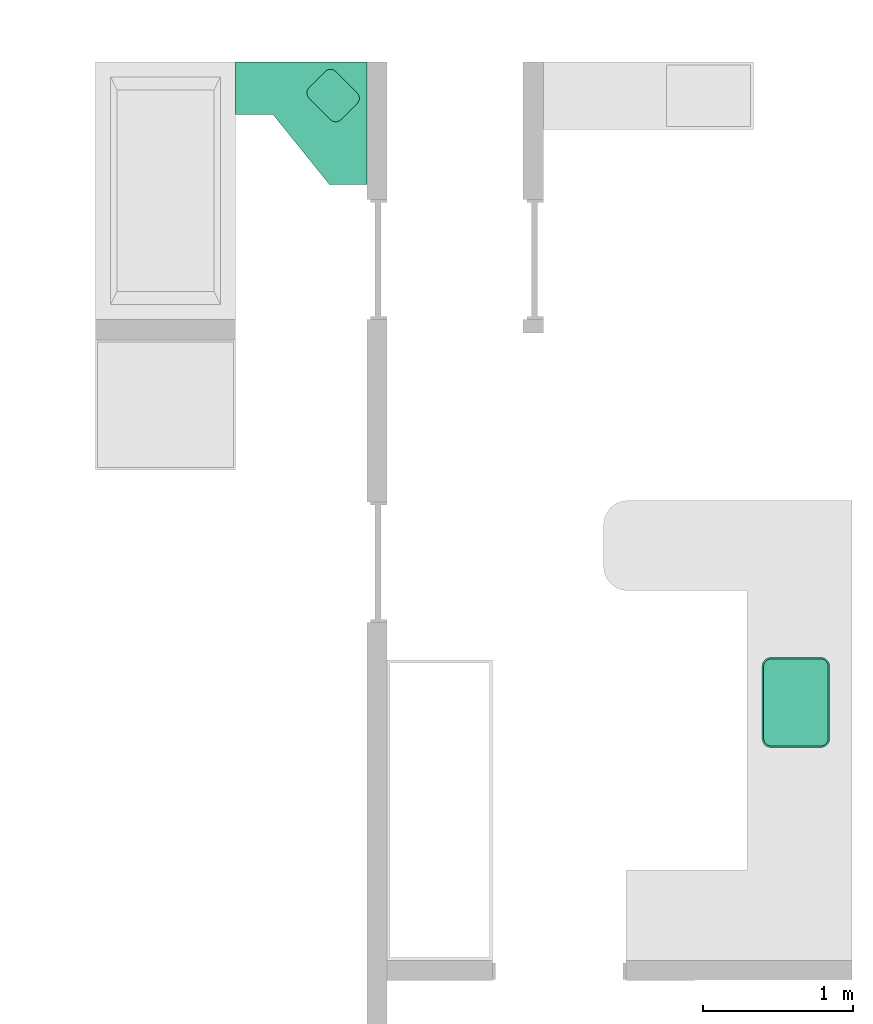
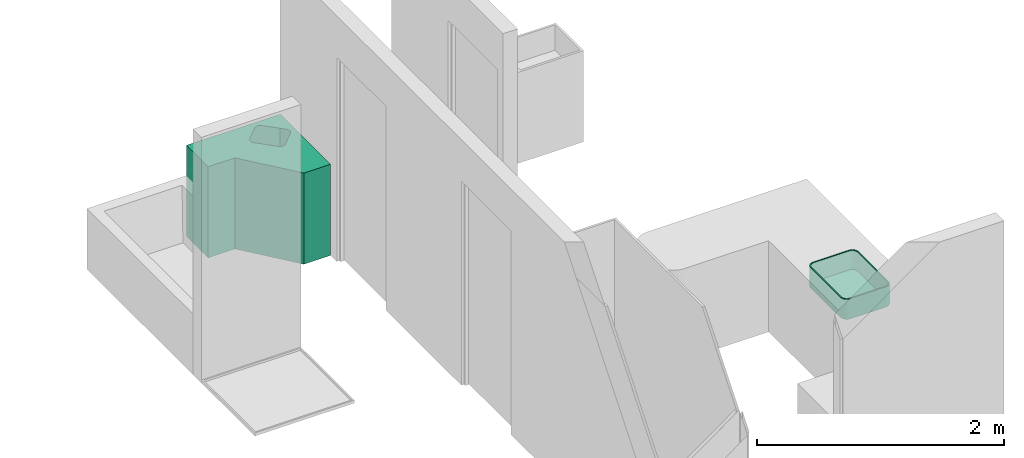
# One storey, part 4 of 6: 2 sanitary terminals.
"""IFC4 building model written with IfcOpenShell, lengths in millimetres."""

from ifc_helpers import new_model, entity, si_unit, converted_unit, frame, origin_with_axes, origin_2d_with_axis, place, context, subcontext, project, spatial, polygons, source, transform, mapped, type_object, type_shapes, element, save


model = new_model("IFC4")

# Units and contexts
model_context = context("Model", 3, precision=1e-05, world=origin_with_axes())
plan_context = context("Plan", 2, precision=1e-05, world=origin_2d_with_axis())
body_context = subcontext(model_context, "Body", "Model", "MODEL_VIEW")
ifc_project = project(units=[si_unit("VOLUMEUNIT", "CUBIC_METRE"), si_unit("LENGTHUNIT", "METRE", prefix="MILLI"), converted_unit("PLANEANGLEUNIT", "degree", entity("IfcReal", 0.0174532925199433), si_unit("PLANEANGLEUNIT", "RADIAN"), dimensions=[0, 0, 0, 0, 0, 0, 0]), si_unit("AREAUNIT", "SQUARE_METRE")], contexts=[model_context, plan_context])

# Site, building, storey
site_placement = place(None, origin_with_axes())
site = spatial("IfcSite", under=ifc_project, at=site_placement)
building_placement = place(site_placement, origin_with_axes())
building = spatial("IfcBuilding", under=site, at=building_placement, Name="Building")
storey_placement = place(building_placement, origin_with_axes())
storey = spatial("IfcBuildingStorey", under=building, at=storey_placement, Name="DEMO")

# Sanitary terminals
sanitary_terminal_type_1 = type_object("IfcSanitaryTerminalType", Name="Cube", PredefinedType="SINK")
shared_shape_1 = source(origin_with_axes(), body_context, "Body", "Tessellation", [
    polygons([(-165.200759887695, -300.0, -99.9999923706055), (-225.0, -240.200775146484, -99.9999923706055), (-183.679748535156, -297.073211669922, -99.9999923706055), (-200.349884033203, -288.579376220703, -99.9999923706055), (-213.579376220703, -275.349884033203, -99.9999923706055), (-222.073226928711, -258.679779052734, -99.9999923706055), (-214.999984741211, -239.413757324219, 99.9999923706055), (-164.413757324219, -290.0, 99.9999923706055), (-212.444091796875, -255.551116943359, 99.9999923706055), (-205.388336181641, -269.398773193359, 99.9999923706055), (-194.398742675781, -280.388366699219, 99.9999923706055), (-180.551071166992, -287.444091796875, 99.9999923706055), (-225.0, 240.200775146484, -99.9999923706055), (-165.200775146484, 300.0, -99.9999923706055), (-222.073211669922, 258.679779052734, -99.9999923706055), (-213.579360961914, 275.349884033203, -99.9999923706055), (-200.349868774414, 288.579376220703, -99.9999923706055), (-183.679748535156, 297.073211669922, -99.9999923706055), (-164.41374206543, 290.0, 99.9999923706055), (-214.999984741211, 239.413772583008, 99.9999923706055), (-180.551071166992, 287.444091796875, 99.9999923706055), (-194.39875793457, 280.388366699219, 99.9999923706055), (-205.38835144043, 269.398773193359, 99.9999923706055), (-212.444107055664, 255.551116943359, 99.9999923706055), (225.0, -240.200775146484, -99.9999923706055), (165.200775146484, -300.0, -99.9999923706055), (222.073211669922, -258.679779052734, -99.9999923706055), (213.579360961914, -275.349884033203, -99.9999923706055), (200.349868774414, -288.579376220703, -99.9999923706055), (183.679748535156, -297.073211669922, -99.9999923706055), (164.41374206543, -290.0, 99.9999923706055), (214.999984741211, -239.413772583008, 99.9999923706055), (180.551071166992, -287.444091796875, 99.9999923706055), (194.39875793457, -280.388366699219, 99.9999923706055), (205.38835144043, -269.398773193359, 99.9999923706055), (212.444107055664, -255.551116943359, 99.9999923706055), (165.200759887695, 300.0, -99.9999923706055), (225.0, 240.200775146484, -99.9999923706055), (183.679748535156, 297.073211669922, -99.9999923706055), (200.349884033203, 288.579376220703, -99.9999923706055), (213.579376220703, 275.349884033203, -99.9999923706055), (222.073226928711, 258.679779052734, -99.9999923706055), (214.999984741211, 239.413757324219, 99.9999923706055), (164.413757324219, 290.0, 99.9999923706055), (212.444091796875, 255.551116943359, 99.9999923706055), (205.38835144043, 269.398773193359, 99.9999923706055), (194.398742675781, 280.388366699219, 99.9999923706055), (180.551071166992, 287.444091796875, 99.9999923706055), (-165.200775146484, -300.0, 99.9999923706055), (-183.679748535156, -297.073211669922, 99.9999923706055), (-200.349868774414, -288.579376220703, 99.9999923706055), (-213.579360961914, -275.349884033203, 99.9999923706055), (-222.073211669922, -258.679779052734, 99.9999923706055), (-225.0, -240.200775146484, 99.9999923706055), (-183.679748535156, 297.073211669922, 99.9999923706055), (-165.200759887695, 300.0, 99.9999923706055), (-200.349884033203, 288.579376220703, 99.9999923706055), (-213.579376220703, 275.349884033203, 99.9999923706055), (-222.073226928711, 258.679779052734, 99.9999923706055), (-225.0, 240.200775146484, 99.9999923706055), (222.073211669922, 258.679779052734, 99.9999923706055), (225.0, 240.200775146484, 99.9999923706055), (213.579360961914, 275.349884033203, 99.9999923706055), (200.349868774414, 288.579376220703, 99.9999923706055), (183.679748535156, 297.073211669922, 99.9999923706055), (165.200775146484, 300.0, 99.9999923706055), (183.679748535156, -297.073211669922, 99.9999923706055), (165.200759887695, -300.0, 99.9999923706055), (200.349884033203, -288.579376220703, 99.9999923706055), (213.579376220703, -275.349884033203, 99.9999923706055), (222.073226928711, -258.679779052734, 99.9999923706055), (225.0, -240.200775146484, 99.9999923706055), (-164.413757324219, -290.0, -90.0000076293945), (-180.551071166992, -287.444091796875, -90.0000076293945), (-194.398742675781, -280.388366699219, -90.0000076293945), (-205.388336181641, -269.398773193359, -90.0000076293945), (-212.444091796875, -255.551116943359, -90.0000076293945), (-214.999984741211, -239.413757324219, -90.0000076293945), (-180.551071166992, 287.444091796875, -90.0000076293945), (-164.41374206543, 290.0, -90.0000076293945), (-194.39875793457, 280.388366699219, -90.0000076293945), (-205.38835144043, 269.398773193359, -90.0000076293945), (-212.444107055664, 255.551116943359, -90.0000076293945), (-214.999984741211, 239.413772583008, -90.0000076293945), (212.444091796875, 255.551116943359, -90.0000076293945), (214.999984741211, 239.413757324219, -90.0000076293945), (205.38835144043, 269.398773193359, -90.0000076293945), (194.398742675781, 280.388366699219, -90.0000076293945), (180.551071166992, 287.444091796875, -90.0000076293945), (164.413757324219, 290.0, -90.0000076293945), (180.551071166992, -287.444091796875, -90.0000076293945), (164.41374206543, -290.0, -90.0000076293945), (194.39875793457, -280.388366699219, -90.0000076293945), (205.38835144043, -269.398773193359, -90.0000076293945), (212.444107055664, -255.551116943359, -90.0000076293945), (214.999984741211, -239.413772583008, -90.0000076293945)], [[[26, 68, 49, 1]], [[38, 62, 72, 25]], [[8, 31, 92, 73]], [[2, 54, 60, 13]], [[14, 56, 66, 37]], [[1, 49, 50, 3]], [[3, 50, 51, 4]], [[4, 51, 52, 5]], [[5, 52, 53, 6]], [[6, 53, 54, 2]], [[56, 14, 18, 55]], [[55, 18, 17, 57]], [[57, 17, 16, 58]], [[58, 16, 15, 59]], [[59, 15, 13, 60]], [[62, 38, 42, 61]], [[61, 42, 41, 63]], [[63, 41, 40, 64]], [[64, 40, 39, 65]], [[65, 39, 37, 66]], [[68, 26, 30, 67]], [[67, 30, 29, 69]], [[69, 29, 28, 70]], [[70, 28, 27, 71]], [[71, 27, 25, 72]], [[13, 15, 16, 17, 18, 14, 37, 39, 40, 41, 42, 38, 25, 27, 28, 29, 30, 26, 1, 3, 4, 5, 6, 2]], [[8, 12, 50, 49]], [[12, 11, 51, 50]], [[11, 10, 52, 51]], [[10, 9, 53, 52]], [[9, 7, 54, 53]], [[21, 19, 56, 55]], [[22, 21, 55, 57]], [[23, 22, 57, 58]], [[24, 23, 58, 59]], [[20, 24, 59, 60]], [[45, 43, 62, 61]], [[46, 45, 61, 63]], [[47, 46, 63, 64]], [[48, 47, 64, 65]], [[44, 48, 65, 66]], [[33, 31, 68, 67]], [[34, 33, 67, 69]], [[35, 34, 69, 70]], [[36, 35, 70, 71]], [[32, 36, 71, 72]], [[7, 20, 60, 54]], [[31, 8, 49, 68]], [[43, 32, 72, 62]], [[19, 44, 66, 56]], [[86, 85, 87, 88, 89, 90, 80, 79, 81, 82, 83, 84, 78, 77, 76, 75, 74, 73, 92, 91, 93, 94, 95, 96]], [[48, 44, 90, 89]], [[22, 23, 82, 81]], [[32, 43, 86, 96]], [[12, 8, 73, 74]], [[31, 33, 91, 92]], [[23, 24, 83, 82]], [[44, 19, 80, 90]], [[11, 12, 74, 75]], [[33, 34, 93, 91]], [[24, 20, 84, 83]], [[10, 11, 75, 76]], [[34, 35, 94, 93]], [[43, 45, 85, 86]], [[9, 10, 76, 77]], [[35, 36, 95, 94]], [[45, 46, 87, 85]], [[7, 9, 77, 78]], [[36, 32, 96, 95]], [[46, 47, 88, 87]], [[19, 21, 79, 80]], [[20, 7, 78, 84]], [[47, 48, 89, 88]], [[21, 22, 81, 79]]], closed=True),
])
type_shapes(sanitary_terminal_type_1, [shared_shape_1])
sanitary_terminal_1_placement = place(storey_placement, frame((12835.0276947021, 1197.83878326416, 805.000066757202), z_axis=(0.0, 0.0, 1.0), x_axis=(1.0, 0.0, 0.0)))
element("IfcSanitaryTerminal", 1, at=sanitary_terminal_1_placement, inside=storey, type_object=sanitary_terminal_type_1, Name="SanitaryTerminal", context=body_context, shape_type="MappedRepresentation", body=[
    mapped(shared_shape_1, transform((0.0, 0.0, 0.0), x_axis=(1.0, 0.0, 0.0), y_axis=(0.0, 1.0, 0.0), z_axis=(0.0, 0.0, 1.0), scale=1.0)),
])
sanitary_terminal_type_2 = type_object("IfcSanitaryTerminalType", PredefinedType="SINK")
shared_shape_2 = source(origin_with_axes(), body_context, "Body", "Tessellation", [
    polygons([(0.0, -184.998504638672, -450.0), (0.0, -534.998474121094, -450.0), (0.0, -184.998504638672, 450.0), (0.0, -534.998474121094, 450.0), (875.000793457031, -999.999938964844, -450.0), (875.000793457031, -999.999938964844, 450.0), (875.000793457031, -184.998504638672, -450.0), (875.000793457031, -184.998504638672, 450.0), (625.000732421875, -999.999938964844, -450.0), (625.000732421875, -999.999938964844, 450.0), (249.999893188477, -534.998352050781, -450.0), (249.999893188477, -534.998352050781, 450.0), (625.000732421875, -999.999938964844, -192.857330322266), (475.917419433594, -384.716705322266, 450.0), (476.097534179688, -399.324768066406, 450.0), (489.515045166016, -425.197570800781, 450.0), (488.700988769531, -359.166931152344, 450.0), (480.782928466797, -413.273559570312, 450.0), (480.260284423828, -370.879241943359, 450.0), (488.700988769531, -359.166900634766, 450.0), (611.973388671875, -239.16618347168, 450.0), (611.973388671875, -239.166198730469, 450.0), (600.261047363281, -247.606887817383, 450.0), (634.802307128906, -570.48486328125, 450.0), (646.726318359375, -579.216918945312, 450.0), (625.810852050781, -234.823333740234, 450.0), (654.36767578125, -239.688842773438, 450.0), (689.12060546875, -579.739624023438, 450.0), (700.832946777344, -571.298889160156, 450.0), (689.12060546875, -579.739624023438, 450.0), (675.283142089844, -584.082458496094, 450.0), (811.578918457031, -393.708190917969, 450.0), (812.392944335938, -459.738861083984, 450.0), (825.176574707031, -434.189086914062, 450.0), (824.996459960938, -419.580993652344, 450.0), (812.392944335938, -459.738891601562, 450.0), (820.833679199219, -448.026550292969, 450.0), (820.311096191406, -405.632232666016, 450.0), (660.675048828125, -583.902404785156, 450.0), (666.291687011719, -248.420944213867, 450.0), (640.418884277344, -235.003433227539, 450.0)], [[[3, 1, 2, 4]], [[1, 3, 8, 7]], [[7, 8, 6, 5]], [[9, 5, 6, 10, 13]], [[11, 2, 1, 7, 5, 9]], [[24, 16, 18, 15, 14, 19, 17, 20, 23, 22, 21, 26, 41, 27, 40, 8, 3, 4, 12, 10, 6, 30, 31, 39, 25]], [[28, 30, 6, 8, 40, 32, 38, 35, 34, 37, 33, 36, 29]], [[10, 12, 11, 9, 13]], [[2, 11, 12, 4]]], closed=False),
])
type_shapes(sanitary_terminal_type_2, [shared_shape_2])
sanitary_terminal_2_placement = place(storey_placement, frame((9104.1202545166, 5646.66700363159, 450.000017881393), z_axis=(0.0, 0.0, 1.0), x_axis=(1.0, 0.0, 0.0)))
element("IfcSanitaryTerminal", 2, at=sanitary_terminal_2_placement, inside=storey, type_object=sanitary_terminal_type_2, Name="SanitaryTerminal", context=body_context, shape_type="MappedRepresentation", body=[
    mapped(shared_shape_2, transform((0.0, 0.0, 0.0), x_axis=(1.0, 0.0, 0.0), y_axis=(0.0, 1.0, 0.0), z_axis=(0.0, 0.0, 1.0), scale=1.0)),
])

save(model, "model.ifc")
